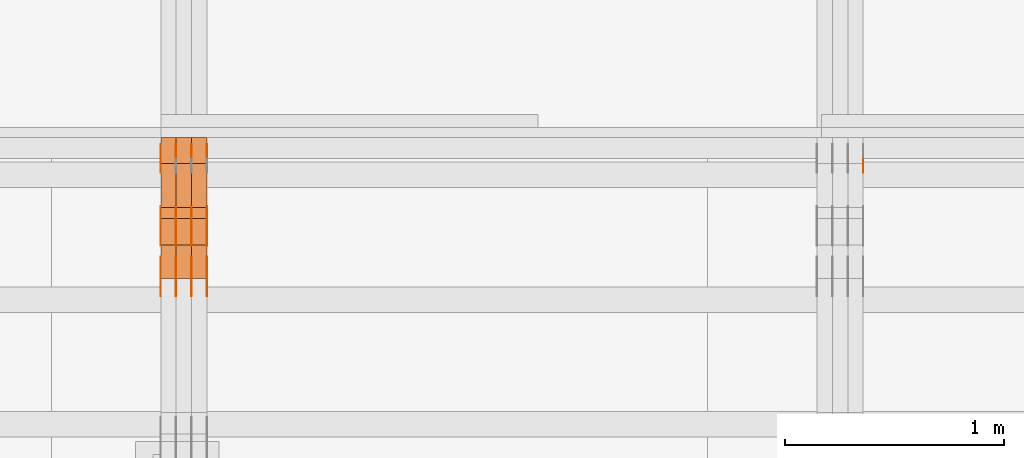
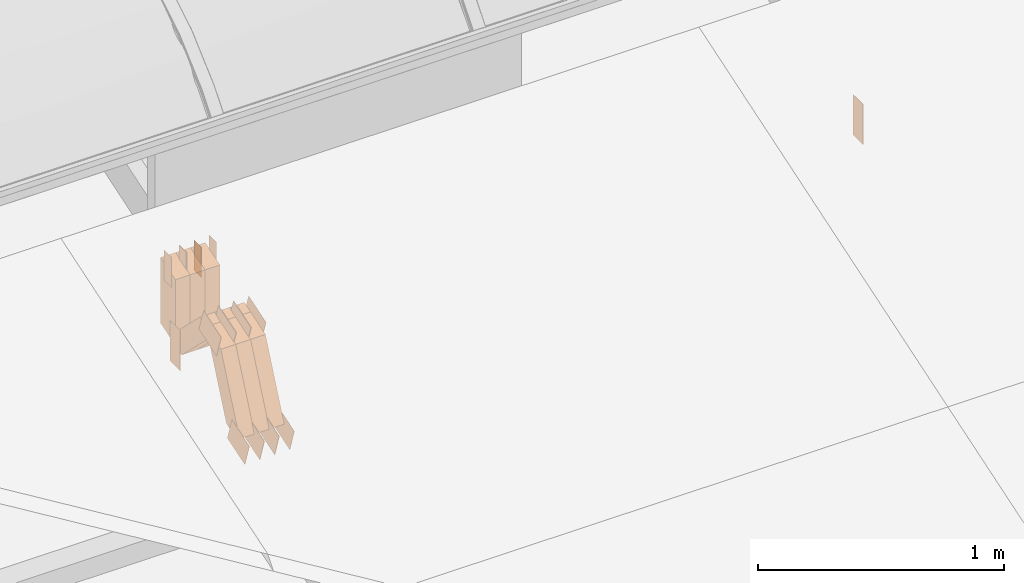
# One storey, part 283 of 385: 29 proxies.
"""IFC2X3 building model written with IfcOpenShell, lengths in millimetres."""

from ifc_helpers import new_model, entity, si_unit, converted_unit, derived_unit, direction, frame, frame_2d, origin, origin_2d_with_axis, place, context, subcontext, project, spatial, polyline, rectangle, outline, extrude, source, transform, mapped, material, type_object, type_shapes, element, save


model = new_model("IFC2X3")

# Units and contexts
model_context = context("Model", 3, precision=0.01, world=origin(), true_north=direction((6.12303176911189e-17, 1.0)))
body_context = subcontext(model_context, "Body", "Model", "MODEL_VIEW")
ifc_project = project(units=[si_unit("LENGTHUNIT", "METRE", prefix="MILLI"), si_unit("AREAUNIT", "SQUARE_METRE"), si_unit("VOLUMEUNIT", "CUBIC_METRE"), converted_unit("PLANEANGLEUNIT", "DEGREE", entity("IfcRatioMeasure", 0.0174532925199433), si_unit("PLANEANGLEUNIT", "RADIAN"), dimensions=[0, 0, 0, 0, 0, 0, 0]), si_unit("MASSUNIT", "GRAM", prefix="KILO"), derived_unit("MASSDENSITYUNIT", [(si_unit("MASSUNIT", "GRAM", prefix="KILO"), 1), (si_unit("LENGTHUNIT", "METRE"), -3)]), si_unit("TIMEUNIT", "SECOND"), si_unit("FREQUENCYUNIT", "HERTZ"), si_unit("THERMODYNAMICTEMPERATUREUNIT", "DEGREE_CELSIUS"), derived_unit("THERMALTRANSMITTANCEUNIT", [(si_unit("MASSUNIT", "GRAM", prefix="KILO"), 1), (si_unit("THERMODYNAMICTEMPERATUREUNIT", "KELVIN"), -1), (si_unit("TIMEUNIT", "SECOND"), -3)]), derived_unit("VOLUMETRICFLOWRATEUNIT", [(si_unit("LENGTHUNIT", "METRE"), 3), (si_unit("TIMEUNIT", "SECOND"), -1)]), si_unit("ELECTRICCURRENTUNIT", "AMPERE"), si_unit("ELECTRICVOLTAGEUNIT", "VOLT"), si_unit("POWERUNIT", "WATT"), si_unit("FORCEUNIT", "NEWTON", prefix="KILO"), si_unit("ILLUMINANCEUNIT", "LUX"), si_unit("LUMINOUSFLUXUNIT", "LUMEN"), si_unit("LUMINOUSINTENSITYUNIT", "CANDELA"), derived_unit("USERDEFINED", [(si_unit("MASSUNIT", "GRAM", prefix="KILO"), -1), (si_unit("LENGTHUNIT", "METRE"), -2), (si_unit("TIMEUNIT", "SECOND"), 3), (si_unit("LUMINOUSFLUXUNIT", "LUMEN"), 1)]), derived_unit("LINEARVELOCITYUNIT", [(si_unit("LENGTHUNIT", "METRE"), 1), (si_unit("TIMEUNIT", "SECOND"), -1)]), si_unit("PRESSUREUNIT", "PASCAL"), derived_unit("USERDEFINED", [(si_unit("LENGTHUNIT", "METRE"), -2), (si_unit("MASSUNIT", "GRAM", prefix="KILO"), 1), (si_unit("TIMEUNIT", "SECOND"), -2)])], contexts=[model_context])

# Site, building, storey
site_placement = place(None, origin())
site = spatial("IfcSite", under=ifc_project, at=site_placement, CompositionType="ELEMENT")
building_placement = place(site_placement, origin())
building = spatial("IfcBuilding", under=site, at=building_placement, CompositionType="ELEMENT")
storey_placement = place(building_placement, origin())
storey = spatial("IfcBuildingStorey", under=building, at=storey_placement, Name="Default", CompositionType="ELEMENT", Elevation=0.0)

# Proxies
ifc_material_1 = material(Name="IfcSurfaceStyle #484596")
building_element_proxy_type_1 = type_object("IfcBuildingElementProxyType", PredefinedType="NOTDEFINED", material=ifc_material_1)
shared_shape_1 = source(origin(), body_context, "Body", "SweptSolid", [
    extrude(rectangle(XDim=200.0, YDim=84.0, at=frame_2d((0.0, -7.105427357601e-15), x_axis=(1.0, 0.0))), frame((100.0, 42.0, 0.0), z_axis=(0.0, 0.0, 1.0), x_axis=(-1.0, 0.0, 0.0)), (0.0, 0.0, 1.0), 1.3),
])
type_shapes(building_element_proxy_type_1, [shared_shape_1])
proxy_1_placement = place(building_placement, frame((39386.3, 13702.0, 3651.4150390625), z_axis=(-1.0, 0.0, 0.0), x_axis=(0.0, 0.0, -1.0)))
element("IfcBuildingElementProxy", 1, at=proxy_1_placement, inside=storey, type_object=building_element_proxy_type_1, material=ifc_material_1, context=body_context, shape_type="MappedRepresentation", body=[
    mapped(shared_shape_1, transform((0.0, 0.0, 0.0), scale=1.0)),
])
ifc_material_2 = material(Name="IfcSurfaceStyle #449879")
building_element_proxy_type_2 = type_object("IfcBuildingElementProxyType", PredefinedType="NOTDEFINED", material=ifc_material_2)
shared_shape_2 = source(origin(), body_context, "Body", "SweptSolid", [
    extrude(rectangle(XDim=200.0, YDim=84.0, at=frame_2d((0.0, -7.105427357601e-15), x_axis=(1.0, 0.0))), frame((100.0, 42.0, 0.0), z_axis=(0.0, 0.0, 1.0), x_axis=(-1.0, 0.0, 0.0)), (0.0, 0.0, 1.0), 1.29999999999999),
])
type_shapes(building_element_proxy_type_2, [shared_shape_2])
proxy_2_placement = place(building_placement, frame((36175.0, 13702.0, 3651.4150390625), z_axis=(-1.0, 0.0, 0.0), x_axis=(0.0, 0.0, -1.0)))
element("IfcBuildingElementProxy", 2, at=proxy_2_placement, inside=storey, type_object=building_element_proxy_type_2, material=ifc_material_2, context=body_context, shape_type="MappedRepresentation", body=[
    mapped(shared_shape_2, transform((0.0, 0.0, 0.0), scale=1.0)),
])
ifc_material_3 = material(Name="IfcSurfaceStyle #449822")
building_element_proxy_type_3 = type_object("IfcBuildingElementProxyType", PredefinedType="NOTDEFINED", material=ifc_material_3)
shared_shape_3 = source(origin(), body_context, "Body", "SweptSolid", [
    extrude(outline(polyline([(-75.0003398116828, -59.9998507501386), (75.0003249421766, -59.9998507501386), (75.0003398116837, 59.9998507501387), (-75.0003249421775, 59.9998507501387), (-75.0003398116828, -59.9998507501386)])), frame((75.0003398116837, 60.0000773549637, 0.0), z_axis=(0.0, 0.0, 1.0), x_axis=(-1.0, 0.0, 0.0)), (0.0, 0.0, 1.0), 1.3),
])
type_shapes(building_element_proxy_type_3, [shared_shape_3])
proxy_3_placement = place(building_placement, frame((36386.3, 13054.73046875, 3417.8388671875), z_axis=(-1.0, 0.0, 0.0), x_axis=(0.0, 0.951056516295124, 0.309016994375039)))
element("IfcBuildingElementProxy", 3, at=proxy_3_placement, inside=storey, type_object=building_element_proxy_type_3, material=ifc_material_3, context=body_context, shape_type="MappedRepresentation", body=[
    mapped(shared_shape_3, transform((0.0, 0.0, 0.0), scale=1.0)),
])
ifc_material_4 = material(Name="IfcSurfaceStyle #449765")
building_element_proxy_type_4 = type_object("IfcBuildingElementProxyType", PredefinedType="NOTDEFINED", material=ifc_material_4)
shared_shape_4 = source(origin(), body_context, "Body", "SweptSolid", [
    extrude(outline(polyline([(-75.0003398116828, -59.9998507501386), (75.0003249421766, -59.9998507501386), (75.0003398116837, 59.9998507501387), (-75.0003249421775, 59.9998507501387), (-75.0003398116828, -59.9998507501386)])), frame((75.0003398116837, 60.0000773549637, 0.0), z_axis=(0.0, 0.0, 1.0), x_axis=(-1.0, 0.0, 0.0)), (0.0, 0.0, 1.0), 1.3),
])
type_shapes(building_element_proxy_type_4, [shared_shape_4])
proxy_4_placement = place(building_placement, frame((36315.0, 13054.73046875, 3417.8388671875), z_axis=(-1.0, 0.0, 0.0), x_axis=(0.0, 0.951056516295124, 0.309016994375039)))
element("IfcBuildingElementProxy", 4, at=proxy_4_placement, inside=storey, type_object=building_element_proxy_type_4, material=ifc_material_4, context=body_context, shape_type="MappedRepresentation", body=[
    mapped(shared_shape_4, transform((0.0, 0.0, 0.0), scale=1.0)),
])
ifc_material_5 = material(Name="IfcSurfaceStyle #449708")
building_element_proxy_type_5 = type_object("IfcBuildingElementProxyType", PredefinedType="NOTDEFINED", material=ifc_material_5)
shared_shape_5 = source(origin(), body_context, "Body", "SweptSolid", [
    extrude(outline(polyline([(-75.0003398116828, -59.9998507501386), (75.0003249421766, -59.9998507501386), (75.0003398116837, 59.9998507501387), (-75.0003249421775, 59.9998507501387), (-75.0003398116828, -59.9998507501386)])), frame((75.0003398116837, 60.0000773549637, 0.0), z_axis=(0.0, 0.0, 1.0), x_axis=(-1.0, 0.0, 0.0)), (0.0, 0.0, 1.0), 1.3),
])
type_shapes(building_element_proxy_type_5, [shared_shape_5])
proxy_5_placement = place(building_placement, frame((36316.3, 13054.73046875, 3417.8388671875), z_axis=(-1.0, 0.0, 0.0), x_axis=(0.0, 0.951056516295124, 0.309016994375039)))
element("IfcBuildingElementProxy", 5, at=proxy_5_placement, inside=storey, type_object=building_element_proxy_type_5, material=ifc_material_5, context=body_context, shape_type="MappedRepresentation", body=[
    mapped(shared_shape_5, transform((0.0, 0.0, 0.0), scale=1.0)),
])
ifc_material_6 = material(Name="IfcSurfaceStyle #449651")
building_element_proxy_type_6 = type_object("IfcBuildingElementProxyType", PredefinedType="NOTDEFINED", material=ifc_material_6)
shared_shape_6 = source(origin(), body_context, "Body", "SweptSolid", [
    extrude(outline(polyline([(-75.0003398116828, -59.9998507501386), (75.0003249421766, -59.9998507501386), (75.0003398116837, 59.9998507501387), (-75.0003249421775, 59.9998507501387), (-75.0003398116828, -59.9998507501386)])), frame((75.0003398116837, 60.0000773549637, 0.0), z_axis=(0.0, 0.0, 1.0), x_axis=(-1.0, 0.0, 0.0)), (0.0, 0.0, 1.0), 1.29999999999999),
])
type_shapes(building_element_proxy_type_6, [shared_shape_6])
proxy_6_placement = place(building_placement, frame((36245.0, 13054.73046875, 3417.8388671875), z_axis=(-1.0, 0.0, 0.0), x_axis=(0.0, 0.951056516295124, 0.309016994375039)))
element("IfcBuildingElementProxy", 6, at=proxy_6_placement, inside=storey, type_object=building_element_proxy_type_6, material=ifc_material_6, context=body_context, shape_type="MappedRepresentation", body=[
    mapped(shared_shape_6, transform((0.0, 0.0, 0.0), scale=1.0)),
])
ifc_material_7 = material(Name="IfcSurfaceStyle #449594")
building_element_proxy_type_7 = type_object("IfcBuildingElementProxyType", PredefinedType="NOTDEFINED", material=ifc_material_7)
shared_shape_7 = source(origin(), body_context, "Body", "SweptSolid", [
    extrude(outline(polyline([(-75.0003398116828, -59.9998507501386), (75.0003249421766, -59.9998507501386), (75.0003398116837, 59.9998507501387), (-75.0003249421775, 59.9998507501387), (-75.0003398116828, -59.9998507501386)])), frame((75.0003398116837, 60.0000773549637, 0.0), z_axis=(0.0, 0.0, 1.0), x_axis=(-1.0, 0.0, 0.0)), (0.0, 0.0, 1.0), 1.29999999999999),
])
type_shapes(building_element_proxy_type_7, [shared_shape_7])
proxy_7_placement = place(building_placement, frame((36246.3, 13054.73046875, 3417.8388671875), z_axis=(-1.0, 0.0, 0.0), x_axis=(0.0, 0.951056516295124, 0.309016994375039)))
element("IfcBuildingElementProxy", 7, at=proxy_7_placement, inside=storey, type_object=building_element_proxy_type_7, material=ifc_material_7, context=body_context, shape_type="MappedRepresentation", body=[
    mapped(shared_shape_7, transform((0.0, 0.0, 0.0), scale=1.0)),
])
ifc_material_8 = material(Name="IfcSurfaceStyle #449537")
building_element_proxy_type_8 = type_object("IfcBuildingElementProxyType", PredefinedType="NOTDEFINED", material=ifc_material_8)
shared_shape_8 = source(origin(), body_context, "Body", "SweptSolid", [
    extrude(outline(polyline([(-75.0003398116828, -59.9998507501386), (75.0003249421766, -59.9998507501386), (75.0003398116837, 59.9998507501387), (-75.0003249421775, 59.9998507501387), (-75.0003398116828, -59.9998507501386)])), frame((75.0003398116837, 60.0000773549637, 0.0), z_axis=(0.0, 0.0, 1.0), x_axis=(-1.0, 0.0, 0.0)), (0.0, 0.0, 1.0), 1.29999999999999),
])
type_shapes(building_element_proxy_type_8, [shared_shape_8])
proxy_8_placement = place(building_placement, frame((36175.0, 13054.73046875, 3417.8388671875), z_axis=(-1.0, 0.0, 0.0), x_axis=(0.0, 0.951056516295124, 0.309016994375039)))
element("IfcBuildingElementProxy", 8, at=proxy_8_placement, inside=storey, type_object=building_element_proxy_type_8, material=ifc_material_8, context=body_context, shape_type="MappedRepresentation", body=[
    mapped(shared_shape_8, transform((0.0, 0.0, 0.0), scale=1.0)),
])
ifc_material_9 = material(Name="IfcSurfaceStyle #441956")
building_element_proxy_type_9 = type_object("IfcBuildingElementProxyType", PredefinedType="NOTDEFINED", material=ifc_material_9)
shared_shape_9 = source(origin(), body_context, "Body", "SweptSolid", [
    extrude(outline(polyline([(-74.999875428623, -60.0000016373506), (74.9998605591059, -60.0000016373506), (74.9998754286239, 60.0000016373506), (-74.9998605591068, 60.0000016373506), (-74.999875428623, -60.0000016373506)])), frame((75.0002691827262, 60.0000190504561, 0.0), z_axis=(0.0, 0.0, 1.0), x_axis=(-1.0, 0.0, 0.0)), (0.0, 0.0, 1.0), 1.3),
])
type_shapes(building_element_proxy_type_9, [shared_shape_9])
proxy_9_placement = place(building_placement, frame((36386.3, 13285.0865109705, 3819.37496637467), z_axis=(-1.0, 0.0, 0.0), x_axis=(0.0, 0.951056516295154, 0.309016994374948)))
element("IfcBuildingElementProxy", 9, at=proxy_9_placement, inside=storey, type_object=building_element_proxy_type_9, material=ifc_material_9, context=body_context, shape_type="MappedRepresentation", body=[
    mapped(shared_shape_9, transform((0.0, 0.0, 0.0), scale=1.0)),
])
ifc_material_10 = material(Name="IfcSurfaceStyle #441899")
building_element_proxy_type_10 = type_object("IfcBuildingElementProxyType", PredefinedType="NOTDEFINED", material=ifc_material_10)
shared_shape_10 = source(origin(), body_context, "Body", "SweptSolid", [
    extrude(outline(polyline([(-74.999875428623, -60.0000016373506), (74.9998605591059, -60.0000016373506), (74.9998754286239, 60.0000016373506), (-74.9998605591068, 60.0000016373506), (-74.999875428623, -60.0000016373506)])), frame((75.0002691827262, 60.0000190504561, 0.0), z_axis=(0.0, 0.0, 1.0), x_axis=(-1.0, 0.0, 0.0)), (0.0, 0.0, 1.0), 1.3),
])
type_shapes(building_element_proxy_type_10, [shared_shape_10])
proxy_10_placement = place(building_placement, frame((36315.0, 13285.0865109705, 3819.37496637467), z_axis=(-1.0, 0.0, 0.0), x_axis=(0.0, 0.951056516295154, 0.309016994374948)))
element("IfcBuildingElementProxy", 10, at=proxy_10_placement, inside=storey, type_object=building_element_proxy_type_10, material=ifc_material_10, context=body_context, shape_type="MappedRepresentation", body=[
    mapped(shared_shape_10, transform((0.0, 0.0, 0.0), scale=1.0)),
])
ifc_material_11 = material(Name="IfcSurfaceStyle #441842")
building_element_proxy_type_11 = type_object("IfcBuildingElementProxyType", PredefinedType="NOTDEFINED", material=ifc_material_11)
shared_shape_11 = source(origin(), body_context, "Body", "SweptSolid", [
    extrude(outline(polyline([(-74.999875428623, -60.0000016373506), (74.9998605591059, -60.0000016373506), (74.9998754286239, 60.0000016373506), (-74.9998605591068, 60.0000016373506), (-74.999875428623, -60.0000016373506)])), frame((75.0002691827262, 60.0000190504561, 0.0), z_axis=(0.0, 0.0, 1.0), x_axis=(-1.0, 0.0, 0.0)), (0.0, 0.0, 1.0), 1.3),
])
type_shapes(building_element_proxy_type_11, [shared_shape_11])
proxy_11_placement = place(building_placement, frame((36316.3, 13285.0865109705, 3819.37496637467), z_axis=(-1.0, 0.0, 0.0), x_axis=(0.0, 0.951056516295154, 0.309016994374948)))
element("IfcBuildingElementProxy", 11, at=proxy_11_placement, inside=storey, type_object=building_element_proxy_type_11, material=ifc_material_11, context=body_context, shape_type="MappedRepresentation", body=[
    mapped(shared_shape_11, transform((0.0, 0.0, 0.0), scale=1.0)),
])
ifc_material_12 = material(Name="IfcSurfaceStyle #441785")
building_element_proxy_type_12 = type_object("IfcBuildingElementProxyType", PredefinedType="NOTDEFINED", material=ifc_material_12)
shared_shape_12 = source(origin(), body_context, "Body", "SweptSolid", [
    extrude(outline(polyline([(-74.999875428623, -60.0000016373506), (74.9998605591059, -60.0000016373506), (74.9998754286239, 60.0000016373506), (-74.9998605591068, 60.0000016373506), (-74.999875428623, -60.0000016373506)])), frame((75.0002691827262, 60.0000190504561, 0.0), z_axis=(0.0, 0.0, 1.0), x_axis=(-1.0, 0.0, 0.0)), (0.0, 0.0, 1.0), 1.29999999999999),
])
type_shapes(building_element_proxy_type_12, [shared_shape_12])
proxy_12_placement = place(building_placement, frame((36245.0, 13285.0865109705, 3819.37496637467), z_axis=(-1.0, 0.0, 0.0), x_axis=(0.0, 0.951056516295154, 0.309016994374948)))
element("IfcBuildingElementProxy", 12, at=proxy_12_placement, inside=storey, type_object=building_element_proxy_type_12, material=ifc_material_12, context=body_context, shape_type="MappedRepresentation", body=[
    mapped(shared_shape_12, transform((0.0, 0.0, 0.0), scale=1.0)),
])
ifc_material_13 = material(Name="IfcSurfaceStyle #441728")
building_element_proxy_type_13 = type_object("IfcBuildingElementProxyType", PredefinedType="NOTDEFINED", material=ifc_material_13)
shared_shape_13 = source(origin(), body_context, "Body", "SweptSolid", [
    extrude(outline(polyline([(-74.999875428623, -60.0000016373506), (74.9998605591059, -60.0000016373506), (74.9998754286239, 60.0000016373506), (-74.9998605591068, 60.0000016373506), (-74.999875428623, -60.0000016373506)])), frame((75.0002691827262, 60.0000190504561, 0.0), z_axis=(0.0, 0.0, 1.0), x_axis=(-1.0, 0.0, 0.0)), (0.0, 0.0, 1.0), 1.29999999999999),
])
type_shapes(building_element_proxy_type_13, [shared_shape_13])
proxy_13_placement = place(building_placement, frame((36246.3, 13285.0865109705, 3819.37496637467), z_axis=(-1.0, 0.0, 0.0), x_axis=(0.0, 0.951056516295154, 0.309016994374948)))
element("IfcBuildingElementProxy", 13, at=proxy_13_placement, inside=storey, type_object=building_element_proxy_type_13, material=ifc_material_13, context=body_context, shape_type="MappedRepresentation", body=[
    mapped(shared_shape_13, transform((0.0, 0.0, 0.0), scale=1.0)),
])
ifc_material_14 = material(Name="IfcSurfaceStyle #441671")
building_element_proxy_type_14 = type_object("IfcBuildingElementProxyType", PredefinedType="NOTDEFINED", material=ifc_material_14)
shared_shape_14 = source(origin(), body_context, "Body", "SweptSolid", [
    extrude(outline(polyline([(-74.999875428623, -60.0000016373506), (74.9998605591059, -60.0000016373506), (74.9998754286239, 60.0000016373506), (-74.9998605591068, 60.0000016373506), (-74.999875428623, -60.0000016373506)])), frame((75.0002691827262, 60.0000190504561, 0.0), z_axis=(0.0, 0.0, 1.0), x_axis=(-1.0, 0.0, 0.0)), (0.0, 0.0, 1.0), 1.29999999999999),
])
type_shapes(building_element_proxy_type_14, [shared_shape_14])
proxy_14_placement = place(building_placement, frame((36175.0, 13285.0865109705, 3819.37496637467), z_axis=(-1.0, 0.0, 0.0), x_axis=(0.0, 0.951056516295154, 0.309016994374948)))
element("IfcBuildingElementProxy", 14, at=proxy_14_placement, inside=storey, type_object=building_element_proxy_type_14, material=ifc_material_14, context=body_context, shape_type="MappedRepresentation", body=[
    mapped(shared_shape_14, transform((0.0, 0.0, 0.0), scale=1.0)),
])
ifc_material_15 = material(Name="IfcSurfaceStyle #441272")
building_element_proxy_type_15 = type_object("IfcBuildingElementProxyType", PredefinedType="NOTDEFINED", material=ifc_material_15)
shared_shape_15 = source(origin(), body_context, "Body", "SweptSolid", [
    extrude(rectangle(XDim=150.0, YDim=60.0, at=origin_2d_with_axis()), frame((75.0000705696166, 30.0, 0.0), z_axis=(0.0, 0.0, 1.0), x_axis=(-1.0, 0.0, 0.0)), (0.0, 0.0, 1.0), 1.3),
])
type_shapes(building_element_proxy_type_15, [shared_shape_15])
proxy_15_placement = place(building_placement, frame((36386.3, 13750.0, 3972.59919166337), z_axis=(-1.0, 0.0, 0.0), x_axis=(0.0, 0.0, -1.0)))
element("IfcBuildingElementProxy", 15, at=proxy_15_placement, inside=storey, type_object=building_element_proxy_type_15, material=ifc_material_15, context=body_context, shape_type="MappedRepresentation", body=[
    mapped(shared_shape_15, transform((0.0, 0.0, 0.0), scale=1.0)),
])
ifc_material_16 = material(Name="IfcSurfaceStyle #441215")
building_element_proxy_type_16 = type_object("IfcBuildingElementProxyType", PredefinedType="NOTDEFINED", material=ifc_material_16)
shared_shape_16 = source(origin(), body_context, "Body", "SweptSolid", [
    extrude(rectangle(XDim=150.0, YDim=60.0, at=origin_2d_with_axis()), frame((75.0000705696166, 30.0, 0.0), z_axis=(0.0, 0.0, 1.0), x_axis=(-1.0, 0.0, 0.0)), (0.0, 0.0, 1.0), 1.3),
])
type_shapes(building_element_proxy_type_16, [shared_shape_16])
proxy_16_placement = place(building_placement, frame((36315.0, 13750.0, 3972.59919166337), z_axis=(-1.0, 0.0, 0.0), x_axis=(0.0, 0.0, -1.0)))
element("IfcBuildingElementProxy", 16, at=proxy_16_placement, inside=storey, type_object=building_element_proxy_type_16, material=ifc_material_16, context=body_context, shape_type="MappedRepresentation", body=[
    mapped(shared_shape_16, transform((0.0, 0.0, 0.0), scale=1.0)),
])
ifc_material_17 = material(Name="IfcSurfaceStyle #441158")
building_element_proxy_type_17 = type_object("IfcBuildingElementProxyType", PredefinedType="NOTDEFINED", material=ifc_material_17)
shared_shape_17 = source(origin(), body_context, "Body", "SweptSolid", [
    extrude(rectangle(XDim=150.0, YDim=60.0, at=origin_2d_with_axis()), frame((75.0000705696166, 30.0, 0.0), z_axis=(0.0, 0.0, 1.0), x_axis=(-1.0, 0.0, 0.0)), (0.0, 0.0, 1.0), 1.3),
])
type_shapes(building_element_proxy_type_17, [shared_shape_17])
proxy_17_placement = place(building_placement, frame((36316.3, 13750.0, 3972.59919166337), z_axis=(-1.0, 0.0, 0.0), x_axis=(0.0, 0.0, -1.0)))
element("IfcBuildingElementProxy", 17, at=proxy_17_placement, inside=storey, type_object=building_element_proxy_type_17, material=ifc_material_17, context=body_context, shape_type="MappedRepresentation", body=[
    mapped(shared_shape_17, transform((0.0, 0.0, 0.0), scale=1.0)),
])
ifc_material_18 = material(Name="IfcSurfaceStyle #441101")
building_element_proxy_type_18 = type_object("IfcBuildingElementProxyType", PredefinedType="NOTDEFINED", material=ifc_material_18)
shared_shape_18 = source(origin(), body_context, "Body", "SweptSolid", [
    extrude(rectangle(XDim=150.0, YDim=60.0, at=origin_2d_with_axis()), frame((75.0000705696166, 30.0, 0.0), z_axis=(0.0, 0.0, 1.0), x_axis=(-1.0, 0.0, 0.0)), (0.0, 0.0, 1.0), 1.29999999999999),
])
type_shapes(building_element_proxy_type_18, [shared_shape_18])
proxy_18_placement = place(building_placement, frame((36245.0, 13750.0, 3972.59919166337), z_axis=(-1.0, 0.0, 0.0), x_axis=(0.0, 0.0, -1.0)))
element("IfcBuildingElementProxy", 18, at=proxy_18_placement, inside=storey, type_object=building_element_proxy_type_18, material=ifc_material_18, context=body_context, shape_type="MappedRepresentation", body=[
    mapped(shared_shape_18, transform((0.0, 0.0, 0.0), scale=1.0)),
])
ifc_material_19 = material(Name="IfcSurfaceStyle #441044")
building_element_proxy_type_19 = type_object("IfcBuildingElementProxyType", PredefinedType="NOTDEFINED", material=ifc_material_19)
shared_shape_19 = source(origin(), body_context, "Body", "SweptSolid", [
    extrude(rectangle(XDim=150.0, YDim=60.0, at=origin_2d_with_axis()), frame((75.0000705696166, 30.0, 0.0), z_axis=(0.0, 0.0, 1.0), x_axis=(-1.0, 0.0, 0.0)), (0.0, 0.0, 1.0), 1.29999999999999),
])
type_shapes(building_element_proxy_type_19, [shared_shape_19])
proxy_19_placement = place(building_placement, frame((36246.3, 13750.0, 3972.59919166337), z_axis=(-1.0, 0.0, 0.0), x_axis=(0.0, 0.0, -1.0)))
element("IfcBuildingElementProxy", 19, at=proxy_19_placement, inside=storey, type_object=building_element_proxy_type_19, material=ifc_material_19, context=body_context, shape_type="MappedRepresentation", body=[
    mapped(shared_shape_19, transform((0.0, 0.0, 0.0), scale=1.0)),
])
ifc_material_20 = material(Name="IfcSurfaceStyle #440987")
building_element_proxy_type_20 = type_object("IfcBuildingElementProxyType", PredefinedType="NOTDEFINED", material=ifc_material_20)
shared_shape_20 = source(origin(), body_context, "Body", "SweptSolid", [
    extrude(rectangle(XDim=150.0, YDim=60.0, at=origin_2d_with_axis()), frame((75.0000705696166, 30.0, 0.0), z_axis=(0.0, 0.0, 1.0), x_axis=(-1.0, 0.0, 0.0)), (0.0, 0.0, 1.0), 1.29999999999999),
])
type_shapes(building_element_proxy_type_20, [shared_shape_20])
proxy_20_placement = place(building_placement, frame((36175.0, 13750.0, 3972.59919166337), z_axis=(-1.0, 0.0, 0.0), x_axis=(0.0, 0.0, -1.0)))
element("IfcBuildingElementProxy", 20, at=proxy_20_placement, inside=storey, type_object=building_element_proxy_type_20, material=ifc_material_20, context=body_context, shape_type="MappedRepresentation", body=[
    mapped(shared_shape_20, transform((0.0, 0.0, 0.0), scale=1.0)),
])
ifc_material_21 = material(Name="IfcSurfaceStyle #431786")
building_element_proxy_type_21 = type_object("IfcBuildingElementProxyType", Name="T1-W49 431784", PredefinedType="NOTDEFINED", material=ifc_material_21)
shared_shape_21 = source(origin(), body_context, "Body", "SweptSolid", [
    extrude(outline(polyline([(-155.175867306415, -47.4997478409253), (152.310664695054, -47.4997478409253), (170.496756790954, -6.14570120142345e-05), (145.70957993751, 47.4998092979374), (-133.37808995724, 47.4998092979373), (-179.963044159863, -6.14570120298391e-05), (-155.175867306415, -47.4997478409253)])), frame((170.496756790954, 47.5001152140455, 0.0), z_axis=(0.0, 0.0, 1.0), x_axis=(-1.0, 0.0, 0.0)), (0.0, 0.0, 1.0), 70.0),
])
type_shapes(building_element_proxy_type_21, [shared_shape_21])
proxy_21_placement = place(building_placement, frame((36385.0, 13443.048524104, 3830.71841973934), z_axis=(-1.0, 0.0, 0.0), x_axis=(0.0, 0.713950095632063, -0.700196587357413)))
element("IfcBuildingElementProxy", 21, at=proxy_21_placement, inside=storey, type_object=building_element_proxy_type_21, material=ifc_material_21, Name="T1-W49", context=body_context, shape_type="MappedRepresentation", body=[
    mapped(shared_shape_21, transform((0.0, 0.0, 0.0), scale=1.0)),
])
ifc_material_22 = material(Name="IfcSurfaceStyle #431711")
building_element_proxy_type_22 = type_object("IfcBuildingElementProxyType", Name="T1-W49 431709", PredefinedType="NOTDEFINED", material=ifc_material_22)
shared_shape_22 = source(origin(), body_context, "Body", "SweptSolid", [
    extrude(outline(polyline([(-155.175867306415, -47.4997478409253), (152.310664695054, -47.4997478409253), (170.496756790954, -6.14570120142345e-05), (145.70957993751, 47.4998092979374), (-133.37808995724, 47.4998092979373), (-179.963044159863, -6.14570120298391e-05), (-155.175867306415, -47.4997478409253)])), frame((170.496756790954, 47.5001152140455, 0.0), z_axis=(0.0, 0.0, 1.0), x_axis=(-1.0, 0.0, 0.0)), (0.0, 0.0, 1.0), 70.0),
])
type_shapes(building_element_proxy_type_22, [shared_shape_22])
proxy_22_placement = place(building_placement, frame((36315.0, 13443.048524104, 3830.71841973934), z_axis=(-1.0, 0.0, 0.0), x_axis=(0.0, 0.713950095632063, -0.700196587357413)))
element("IfcBuildingElementProxy", 22, at=proxy_22_placement, inside=storey, type_object=building_element_proxy_type_22, material=ifc_material_22, Name="T1-W49", context=body_context, shape_type="MappedRepresentation", body=[
    mapped(shared_shape_22, transform((0.0, 0.0, 0.0), scale=1.0)),
])
ifc_material_23 = material(Name="IfcSurfaceStyle #431636")
building_element_proxy_type_23 = type_object("IfcBuildingElementProxyType", Name="T1-W49 431634", PredefinedType="NOTDEFINED", material=ifc_material_23)
shared_shape_23 = source(origin(), body_context, "Body", "SweptSolid", [
    extrude(outline(polyline([(-155.175867306415, -47.4997478409253), (152.310664695054, -47.4997478409253), (170.496756790954, -6.14570120142345e-05), (145.70957993751, 47.4998092979374), (-133.37808995724, 47.4998092979373), (-179.963044159863, -6.14570120298391e-05), (-155.175867306415, -47.4997478409253)])), frame((170.496756790954, 47.5001152140455, 0.0), z_axis=(0.0, 0.0, 1.0), x_axis=(-1.0, 0.0, 0.0)), (0.0, 0.0, 1.0), 70.0),
])
type_shapes(building_element_proxy_type_23, [shared_shape_23])
proxy_23_placement = place(building_placement, frame((36245.0, 13443.048524104, 3830.71841973934), z_axis=(-1.0, 0.0, 0.0), x_axis=(0.0, 0.713950095632063, -0.700196587357413)))
element("IfcBuildingElementProxy", 23, at=proxy_23_placement, inside=storey, type_object=building_element_proxy_type_23, material=ifc_material_23, Name="T1-W49", context=body_context, shape_type="MappedRepresentation", body=[
    mapped(shared_shape_23, transform((0.0, 0.0, 0.0), scale=1.0)),
])
ifc_material_24 = material(Name="IfcSurfaceStyle #431336")
building_element_proxy_type_24 = type_object("IfcBuildingElementProxyType", Name="T1-W1 431334", PredefinedType="NOTDEFINED", material=ifc_material_24)
shared_shape_24 = source(origin(), body_context, "Body", "SweptSolid", [
    extrude(outline(polyline([(-182.839782714844, -60.0), (143.849426269531, -60.0), (182.839660644531, 60.0), (-143.849304199219, 60.0), (-182.839782714844, -60.0)])), frame((182.839674685549, 60.0, 0.0), z_axis=(0.0, 0.0, 1.0), x_axis=(-1.0, 0.0, 0.0)), (0.0, 0.0, 1.0), 70.0),
])
type_shapes(building_element_proxy_type_24, [shared_shape_24])
proxy_24_placement = place(building_placement, frame((36385.0, 13660.0, 3551.41502502148), z_axis=(-1.0, 0.0, 0.0), x_axis=(0.0, 0.0, 1.0)))
element("IfcBuildingElementProxy", 24, at=proxy_24_placement, inside=storey, type_object=building_element_proxy_type_24, material=ifc_material_24, Name="T1-W1", context=body_context, shape_type="MappedRepresentation", body=[
    mapped(shared_shape_24, transform((0.0, 0.0, 0.0), scale=1.0)),
])
ifc_material_25 = material(Name="IfcSurfaceStyle #431279")
building_element_proxy_type_25 = type_object("IfcBuildingElementProxyType", Name="T1-W1 431277", PredefinedType="NOTDEFINED", material=ifc_material_25)
shared_shape_25 = source(origin(), body_context, "Body", "SweptSolid", [
    extrude(outline(polyline([(-182.839782714844, -60.0), (143.849426269531, -60.0), (182.839660644531, 60.0), (-143.849304199219, 60.0), (-182.839782714844, -60.0)])), frame((182.839674685549, 60.0, 0.0), z_axis=(0.0, 0.0, 1.0), x_axis=(-1.0, 0.0, 0.0)), (0.0, 0.0, 1.0), 70.0),
])
type_shapes(building_element_proxy_type_25, [shared_shape_25])
proxy_25_placement = place(building_placement, frame((36315.0, 13660.0, 3551.41502502148), z_axis=(-1.0, 0.0, 0.0), x_axis=(0.0, 0.0, 1.0)))
element("IfcBuildingElementProxy", 25, at=proxy_25_placement, inside=storey, type_object=building_element_proxy_type_25, material=ifc_material_25, Name="T1-W1", context=body_context, shape_type="MappedRepresentation", body=[
    mapped(shared_shape_25, transform((0.0, 0.0, 0.0), scale=1.0)),
])
ifc_material_26 = material(Name="IfcSurfaceStyle #431222")
building_element_proxy_type_26 = type_object("IfcBuildingElementProxyType", Name="T1-W1 431220", PredefinedType="NOTDEFINED", material=ifc_material_26)
shared_shape_26 = source(origin(), body_context, "Body", "SweptSolid", [
    extrude(outline(polyline([(-182.839782714844, -60.0), (143.849426269531, -60.0), (182.839660644531, 60.0), (-143.849304199219, 60.0), (-182.839782714844, -60.0)])), frame((182.839674685549, 60.0, 0.0), z_axis=(0.0, 0.0, 1.0), x_axis=(-1.0, 0.0, 0.0)), (0.0, 0.0, 1.0), 70.0),
])
type_shapes(building_element_proxy_type_26, [shared_shape_26])
proxy_26_placement = place(building_placement, frame((36245.0, 13660.0, 3551.41502502148), z_axis=(-1.0, 0.0, 0.0), x_axis=(0.0, 0.0, 1.0)))
element("IfcBuildingElementProxy", 26, at=proxy_26_placement, inside=storey, type_object=building_element_proxy_type_26, material=ifc_material_26, Name="T1-W1", context=body_context, shape_type="MappedRepresentation", body=[
    mapped(shared_shape_26, transform((0.0, 0.0, 0.0), scale=1.0)),
])
ifc_material_27 = material(Name="IfcSurfaceStyle #430796")
building_element_proxy_type_27 = type_object("IfcBuildingElementProxyType", Name="T1-W42 430794", PredefinedType="NOTDEFINED", material=ifc_material_27)
shared_shape_27 = source(origin(), body_context, "Body", "SweptSolid", [
    extrude(outline(polyline([(-284.837590197601, -47.4997543607933), (129.95880168156, -47.4997543607933), (171.972324990451, 0.000162623346093338), (183.717007105413, 47.4996730491203), (-200.810543579822, 47.4996730491203), (-284.837590197601, -47.4997543607933)])), frame((183.717155718752, 47.4999821655365, 0.0), z_axis=(0.0, 0.0, 1.0), x_axis=(-1.0, 0.0, 0.0)), (0.0, 0.0, 1.0), 70.0),
])
type_shapes(building_element_proxy_type_27, [shared_shape_27])
proxy_27_placement = place(building_placement, frame((36385.0, 13135.8834463264, 3404.958483022), z_axis=(-1.0, 0.0, 0.0), x_axis=(0.0, 0.398630596470292, 0.917111578575769)))
element("IfcBuildingElementProxy", 27, at=proxy_27_placement, inside=storey, type_object=building_element_proxy_type_27, material=ifc_material_27, Name="T1-W42", context=body_context, shape_type="MappedRepresentation", body=[
    mapped(shared_shape_27, transform((0.0, 0.0, 0.0), scale=1.0)),
])
ifc_material_28 = material(Name="IfcSurfaceStyle #430730")
building_element_proxy_type_28 = type_object("IfcBuildingElementProxyType", Name="T1-W42 430728", PredefinedType="NOTDEFINED", material=ifc_material_28)
shared_shape_28 = source(origin(), body_context, "Body", "SweptSolid", [
    extrude(outline(polyline([(-284.837590197601, -47.4997543607933), (129.95880168156, -47.4997543607933), (171.972324990451, 0.000162623346093338), (183.717007105413, 47.4996730491203), (-200.810543579822, 47.4996730491203), (-284.837590197601, -47.4997543607933)])), frame((183.717155718752, 47.4999821655365, 0.0), z_axis=(0.0, 0.0, 1.0), x_axis=(-1.0, 0.0, 0.0)), (0.0, 0.0, 1.0), 70.0),
])
type_shapes(building_element_proxy_type_28, [shared_shape_28])
proxy_28_placement = place(building_placement, frame((36315.0, 13135.8834463264, 3404.958483022), z_axis=(-1.0, 0.0, 0.0), x_axis=(0.0, 0.398630596470292, 0.917111578575769)))
element("IfcBuildingElementProxy", 28, at=proxy_28_placement, inside=storey, type_object=building_element_proxy_type_28, material=ifc_material_28, Name="T1-W42", context=body_context, shape_type="MappedRepresentation", body=[
    mapped(shared_shape_28, transform((0.0, 0.0, 0.0), scale=1.0)),
])
ifc_material_29 = material(Name="IfcSurfaceStyle #430664")
building_element_proxy_type_29 = type_object("IfcBuildingElementProxyType", Name="T1-W42 430662", PredefinedType="NOTDEFINED", material=ifc_material_29)
shared_shape_29 = source(origin(), body_context, "Body", "SweptSolid", [
    extrude(outline(polyline([(-284.837590197601, -47.4997543607933), (129.95880168156, -47.4997543607933), (171.972324990451, 0.000162623346093338), (183.717007105413, 47.4996730491203), (-200.810543579822, 47.4996730491203), (-284.837590197601, -47.4997543607933)])), frame((183.717155718752, 47.4999821655365, 0.0), z_axis=(0.0, 0.0, 1.0), x_axis=(-1.0, 0.0, 0.0)), (0.0, 0.0, 1.0), 70.0),
])
type_shapes(building_element_proxy_type_29, [shared_shape_29])
proxy_29_placement = place(building_placement, frame((36245.0, 13135.8834463264, 3404.958483022), z_axis=(-1.0, 0.0, 0.0), x_axis=(0.0, 0.398630596470292, 0.917111578575769)))
element("IfcBuildingElementProxy", 29, at=proxy_29_placement, inside=storey, type_object=building_element_proxy_type_29, material=ifc_material_29, Name="T1-W42", context=body_context, shape_type="MappedRepresentation", body=[
    mapped(shared_shape_29, transform((0.0, 0.0, 0.0), scale=1.0)),
])

save(model, "model.ifc")
